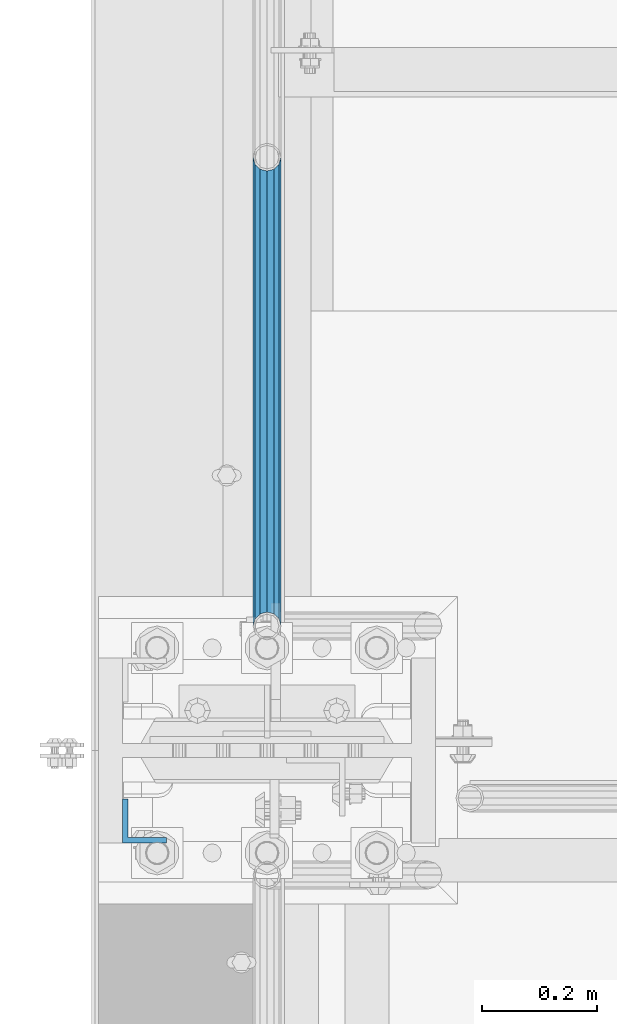
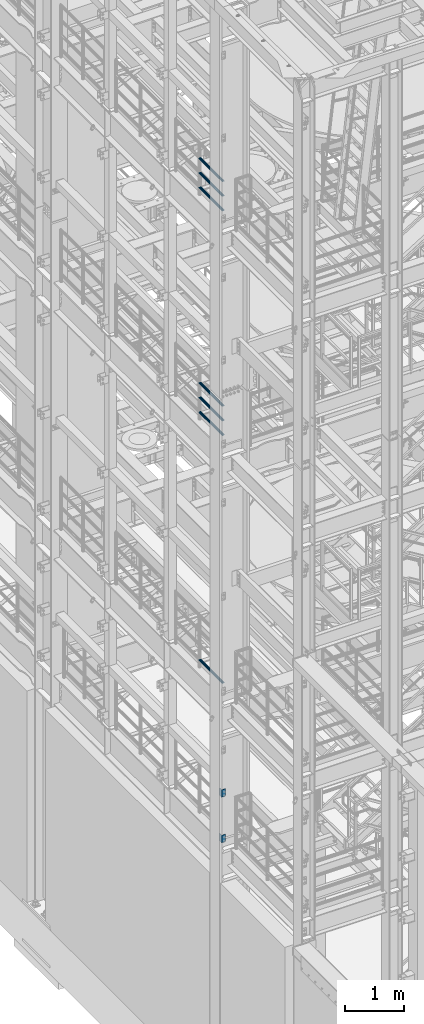
# One storey, part 1161 of 1876: 9 beams, 4 elements without a shape of their own.
"""IFC2X3 building model written with IfcOpenShell, lengths in millimetres."""

import ifcopenshell
import ifcopenshell.guid

model = None  # the IFC model being written
_history = None  # IfcOwnerHistory: only IFC2X3 demands one
_inside = {}  # id of a spatial element -> (the spatial element, [elements in it])
_under = {}  # id of a project, library or spatial element -> (it, [spatial elements below it])
_declared = {}  # id of a project -> (the project, [libraries it declares])
_typed = {}  # id of a type object -> (the type object, [elements of that type])
_made_of = {}  # id of a material, layer set ... -> (it, [elements and type objects made of it])


def new_model(schema):
    """Start an empty IFC model of exactly this schema.

    Asked for "IFC4X3", IfcOpenShell would pick the latest addendum, in which some entities
    have other attributes; the version numbers below select the first issue.
    IFC2X3 requires an IfcOwnerHistory on every rooted entity: one is made here for all.
    """
    global model, _history
    if schema == "IFC4X3":
        model = ifcopenshell.file(schema_version=(4, 3, 0, 0))
    else:
        model = ifcopenshell.file(schema=schema)
    _inside.clear()
    _under.clear()
    _declared.clear()
    _typed.clear()
    _made_of.clear()
    _history = None
    if model.schema == "IFC2X3":
        org = make("IfcOrganization", Name="unknown")
        user = make(
            "IfcPersonAndOrganization",
            ThePerson=make("IfcPerson", FamilyName="unknown"),
            TheOrganization=org,
        )
        app = make(
            "IfcApplication",
            ApplicationDeveloper=org,
            Version="unknown",
            ApplicationFullName="unknown",
            ApplicationIdentifier="unknown",
        )
        _history = make(
            "IfcOwnerHistory",
            OwningUser=user,
            OwningApplication=app,
            ChangeAction="ADDED",
            CreationDate=0,
        )
    return model


def make(cls, **values):
    """One entity of the class cls with the attributes given. An attribute that is None is left unset."""
    return model.create_entity(
        cls, **{name: value for name, value in values.items() if value is not None}
    )


def rooted(cls, **values):
    """An entity with a GlobalId (a new one), such as an element, a storey or a relation."""
    return make(cls, GlobalId=ifcopenshell.guid.new(), OwnerHistory=_history, **values)


def si_unit(unit_type, name, prefix=None):
    """IfcSIUnit, for example si_unit("LENGTHUNIT", "METRE", prefix="MILLI")."""
    return make("IfcSIUnit", UnitType=unit_type, Prefix=prefix, Name=name)


def assignment(units):
    """IfcUnitAssignment: the units of a project."""
    return None if units is None else make("IfcUnitAssignment", Units=units)


def point(xyz):
    """IfcCartesianPoint."""
    return None if xyz is None else make("IfcCartesianPoint", Coordinates=xyz)


def direction(xyz):
    """IfcDirection."""
    return None if xyz is None else make("IfcDirection", DirectionRatios=xyz)


def frame(location, z_axis=None, x_axis=None):
    """IfcAxis2Placement3D, a coordinate frame: its origin and axes. An axis left out is left unset."""
    return make(
        "IfcAxis2Placement3D",
        Location=point(location),
        Axis=direction(z_axis),
        RefDirection=direction(x_axis),
    )


def origin_with_axes():
    """The frame at (0, 0, 0) with the z axis (0, 0, 1) and the x axis (1, 0, 0) written out."""
    return frame((0.0, 0.0, 0.0), z_axis=(0.0, 0.0, 1.0), x_axis=(1.0, 0.0, 0.0))


def place(relative_to, where):
    """IfcLocalPlacement: puts the frame where relative to a parent placement (None: the world)."""
    return make(
        "IfcLocalPlacement", PlacementRelTo=relative_to, RelativePlacement=where
    )


def context(
    kind, dimensions, precision=None, world=None, true_north=None, identifier=None
):
    """IfcGeometricRepresentationContext, for example the 3D "Model" context."""
    return make(
        "IfcGeometricRepresentationContext",
        ContextIdentifier=identifier,
        ContextType=kind,
        CoordinateSpaceDimension=dimensions,
        Precision=precision,
        WorldCoordinateSystem=world,
        TrueNorth=true_north,
    )


def subcontext(parent, identifier, kind, view, scale=None):
    """IfcGeometricRepresentationSubContext, for example "Body" below "Model"."""
    return make(
        "IfcGeometricRepresentationSubContext",
        ContextIdentifier=identifier,
        ContextType=kind,
        ParentContext=parent,
        TargetScale=scale,
        TargetView=view,
    )


def project(units=None, contexts=None):
    """IfcProject with its units and contexts."""
    return rooted(
        "IfcProject",
        Name="project",
        RepresentationContexts=contexts,
        UnitsInContext=assignment(units),
    )


def spatial(cls, under=None, at=None, **own):
    """A site, building, storey or space (cls), placed at a placement, below another one or the project."""
    s = rooted(cls, ObjectPlacement=at, **own)
    if under is not None:
        _under.setdefault(under.id(), (under, []))[1].append(s)
    return s


def faces_of(points, faces, orient=None, outer=None):
    """IfcFace entities. A face is a list of loops; a loop is a list of indices into points, from 0.

    orient and outer hold one flag for each loop. By default every Orientation is true, the
    first loop of a face is its IfcFaceOuterBound and the others are IfcFaceBound.
    """
    made = []
    for i, loops in enumerate(faces):
        bounds = []
        for j, loop in enumerate(loops):
            is_outer = j == 0 if outer is None else outer[i][j]
            bounds.append(
                make(
                    "IfcFaceOuterBound" if is_outer else "IfcFaceBound",
                    Bound=make("IfcPolyLoop", Polygon=[points[k] for k in loop]),
                    Orientation=True if orient is None else orient[i][j],
                )
            )
        made.append(make("IfcFace", Bounds=bounds))
    return made


def faceted_brep(points, faces, orient=None, outer=None, voids=None):
    """IfcFacetedBrep: a solid bounded by flat faces; with voids (closed shells), ...WithVoids."""
    shared = [point(p) for p in points]
    hull = make("IfcClosedShell", CfsFaces=faces_of(shared, faces, orient, outer))
    if voids is None:
        return make("IfcFacetedBrep", Outer=hull)
    return make(
        "IfcFacetedBrepWithVoids",
        Outer=hull,
        Voids=[
            make(cls, CfsFaces=faces_of(shared, fs, o, b)) for cls, fs, o, b in voids
        ],
    )


def shape(context_of_items, identifier, shape_type, items):
    """IfcShapeRepresentation: the items that make up one representation, for example the "Body"."""
    return make(
        "IfcShapeRepresentation",
        ContextOfItems=context_of_items,
        RepresentationIdentifier=identifier,
        RepresentationType=shape_type,
        Items=items,
    )


def material(Name=None, Category=None):
    """IfcMaterial."""
    return make("IfcMaterial", Name=Name, Category=Category)


def made_of(thing, what):
    """Note that an element or type object is made of a material, layer set ...; save() writes the relation."""
    if what is not None:
        _made_of.setdefault(what.id(), (what, []))[1].append(thing)
    return thing


def type_object(cls, material=None, **own):
    """A type object (cls), such as IfcWallType, which elements share."""
    return made_of(rooted(cls, **own), material)


def element(
    cls,
    number,
    at=None,
    inside=None,
    cuts=None,
    type_object=None,
    material=None,
    context=None,
    identifier="Body",
    shape_type=None,
    held_by="IfcProductDefinitionShape",
    body=None,
    shapes=None,
    **own,
):
    """One element of the class cls, such as IfcWall. Its Tag is "e" and its number.

    at: its placement. inside: the storey or other place that contains it. cuts: it is an
    opening in that element (IfcRelVoidsElement). A single representation is given by context,
    identifier, shape_type and body (its items); several are given by shapes. held_by: the class
    of the entity that holds the representations. save() writes the other relations.
    """
    e = rooted(cls, Tag="e%d" % number, ObjectPlacement=at, **own)
    if body is not None:
        shapes = [shape(context, identifier, shape_type, body)]
    if shapes is not None:
        e.Representation = make(held_by, Representations=shapes)
    if inside is not None:
        _inside.setdefault(inside.id(), (inside, []))[1].append(e)
    if cuts is not None:
        rooted(
            "IfcRelVoidsElement", RelatingBuildingElement=cuts, RelatedOpeningElement=e
        )
    if type_object is not None:
        _typed.setdefault(type_object.id(), (type_object, []))[1].append(e)
    return made_of(e, material)


def aggregate(whole, parts):
    """IfcRelAggregates: a whole, such as a stair, and the parts it consists of."""
    return rooted("IfcRelAggregates", RelatingObject=whole, RelatedObjects=parts)


def save(model, path):
    """Write the relations noted so far, then the file.

    IfcRelAggregates (storeys below a building ...), IfcRelContainedInSpatialStructure (elements
    in a storey), IfcRelDefinesByType, IfcRelAssociatesMaterial and IfcRelDeclares: one each for
    every whole, place, type object, material and project.
    """
    for whole, parts in _under.values():
        aggregate(whole, parts)
    for where, things in _inside.values():
        rooted(
            "IfcRelContainedInSpatialStructure",
            RelatedElements=things,
            RelatingStructure=where,
        )
    for kind, things in _typed.values():
        rooted("IfcRelDefinesByType", RelatedObjects=things, RelatingType=kind)
    for what, things in _made_of.values():
        rooted("IfcRelAssociatesMaterial", RelatedObjects=things, RelatingMaterial=what)
    for by, libraries in _declared.values():
        rooted("IfcRelDeclares", RelatingContext=by, RelatedDefinitions=libraries)
    model.write(path)


model = new_model("IFC2X3")

# Units and contexts
model_context = context("Model", 3, precision=1e-05, world=origin_with_axes())
body_context = subcontext(model_context, "Body", "Model", "MODEL_VIEW")
ifc_project = project(units=[si_unit("LENGTHUNIT", "METRE", prefix="MILLI"), si_unit("AREAUNIT", "SQUARE_METRE"), si_unit("VOLUMEUNIT", "CUBIC_METRE"), si_unit("MASSUNIT", "GRAM", prefix="KILO"), si_unit("TIMEUNIT", "SECOND"), si_unit("PLANEANGLEUNIT", "RADIAN"), si_unit("SOLIDANGLEUNIT", "STERADIAN"), si_unit("THERMODYNAMICTEMPERATUREUNIT", "DEGREE_CELSIUS"), si_unit("LUMINOUSINTENSITYUNIT", "LUMEN")], contexts=[model_context])

# Site, building, storey
site_placement = place(None, origin_with_axes())
site = spatial("IfcSite", under=ifc_project, at=site_placement, CompositionType="ELEMENT")
building_placement = place(site_placement, origin_with_axes())
building = spatial("IfcBuilding", under=site, at=building_placement, Name="Undefined", CompositionType="ELEMENT")
storey_placement = place(building_placement, origin_with_axes())
storey = spatial("IfcBuildingStorey", under=building, at=storey_placement, Name="Undefined", CompositionType="ELEMENT", Elevation=0.0)

# Assembly, beams
assembly_1_placement = place(storey_placement, origin_with_axes())
assembly_1 = element("IfcElementAssembly", 1, at=assembly_1_placement, inside=storey, Name="RAIL", AssemblyPlace="NOTDEFINED", PredefinedType="RIGID_FRAME")
ifc_material_1 = material()
beam_type_1 = type_object("IfcBeamType", Name="PIPE1-1/2SCH40", PredefinedType="NOTDEFINED")
beam_1_placement = place(assembly_1_placement, frame((6.13908923696727e-12, -3542.7031, 18145.125), z_axis=(0.0, 0.0, 1.0), x_axis=(0.0, -1.0, 0.0)))
beam_1 = element("IfcBeam", 2, at=beam_1_placement, type_object=beam_type_1, material=ifc_material_1, Name="RAIL", ObjectType="PIPE1-1/2SCH40", context=body_context, shape_type="Brep", body=[
    faceted_brep([(792.499707006684, -12.0649999999996, 20.8971929933177), (792.499707006684, -12.0650000000314, 15.8661214311469), (792.006278568813, -10.2235000000001, 17.7076214311819), (789.266900000001, -9.09494701772928e-13, 20.4470000000001), (789.266900000001, -9.09494701772928e-13, 24.130000000001), (792.00627856883, 10.2235000000001, 17.7076214311819), (792.499707006684, 12.0649999999678, 15.8661214312124), (792.499707006684, 12.0649999999996, 20.8971929933177), (813.396900000002, 24.1300000000001, 0.0), (801.331900000001, 20.8971929933186, 12.0649999999987), (801.331900000001, 20.8971929933186, -12.0649999999987), (798.142328437896, 17.7076214311801, 10.2235000000001), (800.881707006714, 20.4470000000001, 0.0), (798.142328437896, 17.7076214311801, -10.2235000000001), (792.499707006684, 12.0649999999678, -15.8661214312124), (792.499707006684, 12.0649999999996, -20.8971929933177), (792.00627856883, 10.2235000000001, -17.7076214311819), (789.266900000001, 0.0, -20.4470000000001), (789.266900000001, 0.0, -24.130000000001), (792.499707006684, -12.0650000000314, -15.8661214311469), (792.499707006684, -12.0649999999996, -20.8971929933177), (792.006278568813, -10.2235000000001, -17.7076214311819), (813.396900000002, -24.1300000000319, 0.0), (801.331900000001, -20.8971929933186, -12.0649999999987), (801.331900000001, -20.8971929933186, 12.0649999999987), (798.142328437831, -17.7076214311801, -10.2235000000001), (800.881707006651, -20.4470000000001, 0.0), (798.142328437831, -17.7076214311801, 10.2235000000001), (12.0650000000064, -20.8971929933177, -12.0649999999987), (20.8971929933249, -12.0650000000005, -20.8971929933177), (0.0, 24.1299999999992, 0.0), (12.0650000000064, 20.8971929933177, -12.0649999999987), (12.0650000000064, 20.8971929933177, 12.0649999999987), (20.8971929933249, 12.0650000000005, 20.8971929933177), (24.1300000000064, 0.0, 24.130000000001), (20.8971929933249, 12.0650000000005, -20.8971929933177), (24.1300000000063, 0.0, -24.130000000001), (24.1300000000063, 0.0, -20.4470000000001), (20.8971929933249, -12.0650000000005, -15.8661214311796), (21.3906214311868, -10.2235000000001, -17.7076214311819), (21.3906214311868, 10.2235000000001, -17.7076214311819), (20.8971929933249, 12.0650000000005, -15.8661214311796), (15.2545715621445, 17.7076214311801, -10.2235000000001), (12.5151929933249, 20.4470000000001, 0.0), (15.2545715621445, 17.7076214311801, 10.2235000000001), (20.8971929933249, 12.0650000000005, 15.8661214311796), (21.3906214311868, 10.2235000000001, 17.7076214311819), (24.1300000000064, 0.0, 20.4470000000001), (21.3906214311868, -10.2235000000001, 17.7076214311819), (20.8971929933249, -12.0650000000005, 15.8661214311796), (20.8971929933249, -12.0650000000005, 20.8971929933177), (12.0650000000064, -20.8971929933177, 12.0649999999987), (0.0, -24.1299999999992, 0.0), (15.2545715621445, -17.7076214311801, 10.2235000000001), (12.5151929933249, -20.4470000000001, 0.0), (15.2545715621445, -17.7076214311801, -10.2235000000001)], [[[0, 1, 2, 3, 4]], [[4, 3, 5, 6, 7]], [[8, 9, 10]], [[7, 6, 11, 12, 13, 14, 15, 10, 9]], [[16, 17, 18, 15, 14]], [[19, 20, 18, 17, 21]], [[22, 23, 24]], [[24, 23, 20, 19, 25, 26, 27, 1, 0]], [[28, 29, 20, 23]], [[30, 31, 32]], [[33, 34, 4, 7]], [[32, 33, 7, 9]], [[30, 32, 9, 8]], [[31, 30, 8, 10]], [[35, 31, 10, 15]], [[36, 35, 15, 18]], [[29, 36, 18, 20]], [[37, 36, 29, 38, 39]], [[40, 41, 35, 36, 37]], [[32, 31, 35, 41, 42, 43, 44, 45, 33]], [[33, 45, 46, 47, 34]], [[34, 47, 48, 49, 50]], [[34, 50, 0, 4]], [[50, 51, 24, 0]], [[51, 52, 22, 24]], [[52, 28, 23, 22]], [[51, 28, 52]], [[50, 49, 53, 54, 55, 38, 29, 28, 51]], [[55, 54, 26, 25]], [[21, 39, 38, 55, 25, 19]], [[37, 39, 21, 17]], [[40, 37, 17, 16]], [[42, 41, 40, 16, 14, 13]], [[43, 42, 13, 12]], [[44, 43, 12, 11]], [[5, 46, 45, 44, 11, 6]], [[47, 46, 5, 3]], [[48, 47, 3, 2]], [[53, 49, 48, 2, 1, 27]], [[54, 53, 27, 26]]]),
])
beam_2_placement = place(assembly_1_placement, frame((-1.00044417195022e-11, -4356.1, 18449.925000036), z_axis=(0.0, 0.0, -1.0), x_axis=(0.0, 1.0, 0.0)))
beam_2 = element("IfcBeam", 3, at=beam_2_placement, type_object=beam_type_1, material=ifc_material_1, Name="RAIL", ObjectType="PIPE1-1/2SCH40", context=body_context, shape_type="Brep", body=[
    faceted_brep([(0.0, 24.1299999999992, 0.0), (12.0650000000064, 20.8971929933177, -12.0649999999987), (12.0650000000064, 20.8971929933177, 12.0649999999987), (12.0650000000064, -20.8971929933177, 12.0649999999987), (12.0650000000064, -20.8971929933177, -12.0649999999987), (0.0, -24.1299999999992, 0.0), (20.8971929933249, -12.0650000000005, 20.8971929933177), (20.8971929933249, -12.0650000000005, 15.8661214311796), (15.2545715621445, -17.7076214311801, 10.2235000000001), (12.5151929933249, -20.4470000000001, 0.0), (15.2545715621445, -17.7076214311801, -10.2235000000001), (20.8971929933249, -12.0650000000005, -15.8661214311796), (20.8971929933249, -12.0650000000005, -20.8971929933177), (24.1300000000063, 0.0, -20.4470000000001), (24.1300000000063, 0.0, -24.130000000001), (21.3906214311868, -10.2235000000001, -17.7076214311819), (21.3906214311868, 10.2235000000001, -17.7076214311819), (20.8971929933249, 12.0650000000005, -15.8661214311796), (20.8971929933249, 12.0650000000005, -20.8971929933177), (15.2545715621445, 17.7076214311801, -10.2235000000001), (12.5151929933249, 20.4470000000001, 0.0), (15.2545715621445, 17.7076214311801, 10.2235000000001), (20.8971929933249, 12.0650000000005, 15.8661214311796), (20.8971929933249, 12.0650000000005, 20.8971929933177), (21.3906214311868, 10.2235000000001, 17.7076214311819), (24.1300000000064, 0.0, 20.4470000000001), (24.1300000000064, 0.0, 24.130000000001), (21.3906214311868, -10.2235000000001, 17.7076214311819), (813.396900000002, 24.1300000000001, 0.0), (801.331900000001, 20.8971929933186, -12.0649999999987), (792.499707006684, 12.0649999999996, -20.8971929933177), (813.396900000002, -24.1300000000319, 0.0), (801.331900000001, -20.8971929933186, -12.0649999999987), (801.331900000001, -20.8971929933186, 12.0649999999987), (792.499707006684, -12.0649999999996, 20.8971929933177), (792.499707006684, -12.0649999999996, -20.8971929933177), (789.266900000001, 0.0, -24.130000000001), (792.00627856883, 10.2235000000001, -17.7076214311819), (789.266900000001, 0.0, -20.4470000000001), (792.499707006684, 12.0649999999678, -15.8661214312124), (792.499707006684, -12.0650000000314, -15.8661214311469), (792.006278568813, -10.2235000000001, -17.7076214311819), (798.142328437831, -17.7076214311801, -10.2235000000001), (800.881707006651, -20.4470000000001, 0.0), (798.142328437831, -17.7076214311801, 10.2235000000001), (792.499707006684, -12.0650000000314, 15.8661214311469), (792.006278568813, -10.2235000000001, 17.7076214311819), (789.266900000001, -9.09494701772928e-13, 20.4470000000001), (789.266900000001, -9.09494701772928e-13, 24.130000000001), (792.499707006684, 12.0649999999996, 20.8971929933177), (801.331900000001, 20.8971929933186, 12.0649999999987), (792.499707006684, 12.0649999999678, 15.8661214312124), (798.142328437896, 17.7076214311801, 10.2235000000001), (800.881707006714, 20.4470000000001, 0.0), (798.142328437896, 17.7076214311801, -10.2235000000001), (792.00627856883, 10.2235000000001, 17.7076214311819)], [[[0, 1, 2]], [[3, 4, 5]], [[6, 7, 8, 9, 10, 11, 12, 4, 3]], [[13, 14, 12, 11, 15]], [[16, 17, 18, 14, 13]], [[2, 1, 18, 17, 19, 20, 21, 22, 23]], [[23, 22, 24, 25, 26]], [[26, 25, 27, 7, 6]], [[1, 0, 28, 29]], [[18, 1, 29, 30]], [[31, 32, 33]], [[6, 3, 33, 34]], [[3, 5, 31, 33]], [[5, 4, 32, 31]], [[4, 12, 35, 32]], [[12, 14, 36, 35]], [[14, 18, 30, 36]], [[37, 38, 36, 30, 39]], [[40, 35, 36, 38, 41]], [[33, 32, 35, 40, 42, 43, 44, 45, 34]], [[34, 45, 46, 47, 48]], [[26, 6, 34, 48]], [[2, 23, 49, 50]], [[23, 26, 48, 49]], [[0, 2, 50, 28]], [[28, 50, 29]], [[49, 51, 52, 53, 54, 39, 30, 29, 50]], [[48, 47, 55, 51, 49]], [[25, 24, 55, 47]], [[55, 24, 22, 21, 52, 51]], [[21, 20, 53, 52]], [[20, 19, 54, 53]], [[19, 17, 16, 37, 39, 54]], [[16, 13, 38, 37]], [[13, 15, 41, 38]], [[41, 15, 11, 10, 42, 40]], [[10, 9, 43, 42]], [[9, 8, 44, 43]], [[8, 7, 27, 46, 45, 44]], [[27, 25, 47, 46]]]),
])
beam_3_placement = place(assembly_1_placement, frame((-1.00044417195022e-11, -4356.1, 18754.7250000359), z_axis=(0.0, 0.0, -1.0), x_axis=(0.0, 1.0, 0.0)))
beam_3 = element("IfcBeam", 4, at=beam_3_placement, type_object=beam_type_1, material=ifc_material_1, Name="RAIL", ObjectType="PIPE1-1/2SCH40", context=body_context, shape_type="Brep", body=[
    faceted_brep([(0.0, 24.1299999999992, 0.0), (12.0650000000064, 20.8971929933177, -12.0649999999987), (12.0650000000064, 20.8971929933177, 12.0649999999987), (12.0650000000064, -20.8971929933177, 12.0649999999987), (12.0650000000064, -20.8971929933177, -12.0649999999987), (0.0, -24.1299999999992, 0.0), (20.8971929933249, -12.0650000000005, 20.8971929933177), (20.8971929933249, -12.0650000000005, 15.8661214311796), (15.2545715621445, -17.7076214311801, 10.2235000000001), (12.5151929933249, -20.4470000000001, 0.0), (15.2545715621445, -17.7076214311801, -10.2235000000001), (20.8971929933249, -12.0650000000005, -15.8661214311796), (20.8971929933249, -12.0650000000005, -20.8971929933177), (24.1300000000063, 0.0, -20.4470000000001), (24.1300000000063, 0.0, -24.130000000001), (21.3906214311868, -10.2235000000001, -17.7076214311819), (21.3906214311868, 10.2235000000001, -17.7076214311819), (20.8971929933249, 12.0650000000005, -15.8661214311796), (20.8971929933249, 12.0650000000005, -20.8971929933177), (15.2545715621445, 17.7076214311801, -10.2235000000001), (12.5151929933249, 20.4470000000001, 0.0), (15.2545715621445, 17.7076214311801, 10.2235000000001), (20.8971929933249, 12.0650000000005, 15.8661214311796), (20.8971929933249, 12.0650000000005, 20.8971929933177), (21.3906214311868, 10.2235000000001, 17.7076214311819), (24.1300000000064, 0.0, 20.4470000000001), (24.1300000000064, 0.0, 24.130000000001), (21.3906214311868, -10.2235000000001, 17.7076214311819), (813.396900000002, 24.1300000000001, 0.0), (801.331900000001, 20.8971929933186, -12.0649999999987), (792.499707006684, 12.0649999999996, -20.8971929933177), (813.396900000002, -24.1300000000319, 0.0), (801.331900000001, -20.8971929933186, -12.0649999999987), (801.331900000001, -20.8971929933186, 12.0649999999987), (792.499707006684, -12.0649999999996, 20.8971929933177), (792.499707006684, -12.0649999999996, -20.8971929933177), (789.266900000001, 0.0, -24.130000000001), (792.00627856883, 10.2235000000001, -17.7076214311819), (789.266900000001, 0.0, -20.4470000000001), (792.499707006684, 12.0649999999678, -15.8661214312124), (792.499707006684, -12.0650000000314, -15.8661214311469), (792.006278568813, -10.2235000000001, -17.7076214311819), (798.142328437831, -17.7076214311801, -10.2235000000001), (800.881707006651, -20.4470000000001, 0.0), (798.142328437831, -17.7076214311801, 10.2235000000001), (792.499707006684, -12.0650000000314, 15.8661214311469), (792.006278568813, -10.2235000000001, 17.7076214311819), (789.266900000001, -9.09494701772928e-13, 20.4470000000001), (789.266900000001, -9.09494701772928e-13, 24.130000000001), (792.499707006684, 12.0649999999996, 20.8971929933177), (801.331900000001, 20.8971929933186, 12.0649999999987), (792.499707006684, 12.0649999999678, 15.8661214312124), (798.142328437896, 17.7076214311801, 10.2235000000001), (800.881707006714, 20.4470000000001, 0.0), (798.142328437896, 17.7076214311801, -10.2235000000001), (792.00627856883, 10.2235000000001, 17.7076214311819)], [[[0, 1, 2]], [[3, 4, 5]], [[6, 7, 8, 9, 10, 11, 12, 4, 3]], [[13, 14, 12, 11, 15]], [[16, 17, 18, 14, 13]], [[2, 1, 18, 17, 19, 20, 21, 22, 23]], [[23, 22, 24, 25, 26]], [[26, 25, 27, 7, 6]], [[1, 0, 28, 29]], [[18, 1, 29, 30]], [[31, 32, 33]], [[6, 3, 33, 34]], [[3, 5, 31, 33]], [[5, 4, 32, 31]], [[4, 12, 35, 32]], [[12, 14, 36, 35]], [[14, 18, 30, 36]], [[37, 38, 36, 30, 39]], [[40, 35, 36, 38, 41]], [[33, 32, 35, 40, 42, 43, 44, 45, 34]], [[34, 45, 46, 47, 48]], [[26, 6, 34, 48]], [[2, 23, 49, 50]], [[23, 26, 48, 49]], [[0, 2, 50, 28]], [[28, 50, 29]], [[49, 51, 52, 53, 54, 39, 30, 29, 50]], [[48, 47, 55, 51, 49]], [[25, 24, 55, 47]], [[55, 24, 22, 21, 52, 51]], [[21, 20, 53, 52]], [[20, 19, 54, 53]], [[19, 17, 16, 37, 39, 54]], [[16, 13, 38, 37]], [[13, 15, 41, 38]], [[41, 15, 11, 10, 42, 40]], [[10, 9, 43, 42]], [[9, 8, 44, 43]], [[8, 7, 27, 46, 45, 44]], [[27, 25, 47, 46]]]),
])
aggregate(assembly_1, [beam_1, beam_2, beam_3])

assembly_2_placement = place(storey_placement, origin_with_axes())
assembly_2 = element("IfcElementAssembly", 5, at=assembly_2_placement, inside=storey, Name="RAIL", AssemblyPlace="NOTDEFINED", PredefinedType="RIGID_FRAME")
beam_4_placement = place(assembly_2_placement, frame((6.13908923696727e-12, -3542.7031, 13471.525), z_axis=(0.0, 0.0, 1.0), x_axis=(0.0, -1.0, 0.0)))
beam_4 = element("IfcBeam", 6, at=beam_4_placement, type_object=beam_type_1, material=ifc_material_1, Name="RAIL", ObjectType="PIPE1-1/2SCH40", context=body_context, shape_type="Brep", body=[
    faceted_brep([(792.499707006684, -12.0649999999996, 20.8971929933177), (792.499707006684, -12.0650000000314, 15.8661214311469), (792.006278568813, -10.2235000000001, 17.7076214311819), (789.266900000001, -9.09494701772928e-13, 20.4470000000001), (789.266900000001, -9.09494701772928e-13, 24.130000000001), (792.00627856883, 10.2235000000001, 17.7076214311819), (792.499707006684, 12.0649999999678, 15.8661214312124), (792.499707006684, 12.0649999999996, 20.8971929933177), (813.396900000002, 24.1300000000001, 0.0), (801.331900000001, 20.8971929933186, 12.0649999999987), (801.331900000001, 20.8971929933186, -12.0649999999987), (798.142328437896, 17.7076214311801, 10.2235000000001), (800.881707006714, 20.4470000000001, 0.0), (798.142328437896, 17.7076214311801, -10.2235000000001), (792.499707006684, 12.0649999999678, -15.8661214312124), (792.499707006684, 12.0649999999996, -20.8971929933177), (792.00627856883, 10.2235000000001, -17.7076214311819), (789.266900000001, 0.0, -20.4470000000001), (789.266900000001, 0.0, -24.130000000001), (792.499707006684, -12.0650000000314, -15.8661214311469), (792.499707006684, -12.0649999999996, -20.8971929933177), (792.006278568813, -10.2235000000001, -17.7076214311819), (813.396900000002, -24.1300000000319, 0.0), (801.331900000001, -20.8971929933186, -12.0649999999987), (801.331900000001, -20.8971929933186, 12.0649999999987), (798.142328437831, -17.7076214311801, -10.2235000000001), (800.881707006651, -20.4470000000001, 0.0), (798.142328437831, -17.7076214311801, 10.2235000000001), (12.0650000000064, -20.8971929933177, -12.0649999999987), (20.8971929933249, -12.0650000000005, -20.8971929933177), (0.0, 24.1299999999992, 0.0), (12.0650000000064, 20.8971929933177, -12.0649999999987), (12.0650000000064, 20.8971929933177, 12.0649999999987), (20.8971929933249, 12.0650000000005, 20.8971929933177), (24.1300000000064, 0.0, 24.130000000001), (20.8971929933249, 12.0650000000005, -20.8971929933177), (24.1300000000063, 0.0, -24.130000000001), (24.1300000000063, 0.0, -20.4470000000001), (20.8971929933249, -12.0650000000005, -15.8661214311796), (21.3906214311868, -10.2235000000001, -17.7076214311819), (21.3906214311868, 10.2235000000001, -17.7076214311819), (20.8971929933249, 12.0650000000005, -15.8661214311796), (15.2545715621445, 17.7076214311801, -10.2235000000001), (12.5151929933249, 20.4470000000001, 0.0), (15.2545715621445, 17.7076214311801, 10.2235000000001), (20.8971929933249, 12.0650000000005, 15.8661214311796), (21.3906214311868, 10.2235000000001, 17.7076214311819), (24.1300000000064, 0.0, 20.4470000000001), (21.3906214311868, -10.2235000000001, 17.7076214311819), (20.8971929933249, -12.0650000000005, 15.8661214311796), (20.8971929933249, -12.0650000000005, 20.8971929933177), (12.0650000000064, -20.8971929933177, 12.0649999999987), (0.0, -24.1299999999992, 0.0), (15.2545715621445, -17.7076214311801, 10.2235000000001), (12.5151929933249, -20.4470000000001, 0.0), (15.2545715621445, -17.7076214311801, -10.2235000000001)], [[[0, 1, 2, 3, 4]], [[4, 3, 5, 6, 7]], [[8, 9, 10]], [[7, 6, 11, 12, 13, 14, 15, 10, 9]], [[16, 17, 18, 15, 14]], [[19, 20, 18, 17, 21]], [[22, 23, 24]], [[24, 23, 20, 19, 25, 26, 27, 1, 0]], [[28, 29, 20, 23]], [[30, 31, 32]], [[33, 34, 4, 7]], [[32, 33, 7, 9]], [[30, 32, 9, 8]], [[31, 30, 8, 10]], [[35, 31, 10, 15]], [[36, 35, 15, 18]], [[29, 36, 18, 20]], [[37, 36, 29, 38, 39]], [[40, 41, 35, 36, 37]], [[32, 31, 35, 41, 42, 43, 44, 45, 33]], [[33, 45, 46, 47, 34]], [[34, 47, 48, 49, 50]], [[34, 50, 0, 4]], [[50, 51, 24, 0]], [[51, 52, 22, 24]], [[52, 28, 23, 22]], [[51, 28, 52]], [[50, 49, 53, 54, 55, 38, 29, 28, 51]], [[55, 54, 26, 25]], [[21, 39, 38, 55, 25, 19]], [[37, 39, 21, 17]], [[40, 37, 17, 16]], [[42, 41, 40, 16, 14, 13]], [[43, 42, 13, 12]], [[44, 43, 12, 11]], [[5, 46, 45, 44, 11, 6]], [[47, 46, 5, 3]], [[48, 47, 3, 2]], [[53, 49, 48, 2, 1, 27]], [[54, 53, 27, 26]]]),
])
beam_5_placement = place(assembly_2_placement, frame((-1.00044417195022e-11, -4356.1, 13776.325000036), z_axis=(0.0, 0.0, -1.0), x_axis=(0.0, 1.0, 0.0)))
beam_5 = element("IfcBeam", 7, at=beam_5_placement, type_object=beam_type_1, material=ifc_material_1, Name="RAIL", ObjectType="PIPE1-1/2SCH40", context=body_context, shape_type="Brep", body=[
    faceted_brep([(0.0, 24.1299999999992, 0.0), (12.0650000000064, 20.8971929933177, -12.0649999999987), (12.0650000000064, 20.8971929933177, 12.0649999999987), (12.0650000000064, -20.8971929933177, 12.0649999999987), (12.0650000000064, -20.8971929933177, -12.0649999999987), (0.0, -24.1299999999992, 0.0), (20.8971929933249, -12.0650000000005, 20.8971929933177), (20.8971929933249, -12.0650000000005, 15.8661214311796), (15.2545715621445, -17.7076214311801, 10.2235000000001), (12.5151929933249, -20.4470000000001, 0.0), (15.2545715621445, -17.7076214311801, -10.2235000000001), (20.8971929933249, -12.0650000000005, -15.8661214311796), (20.8971929933249, -12.0650000000005, -20.8971929933177), (24.1300000000063, 0.0, -20.4470000000001), (24.1300000000063, 0.0, -24.130000000001), (21.3906214311868, -10.2235000000001, -17.7076214311819), (21.3906214311868, 10.2235000000001, -17.7076214311819), (20.8971929933249, 12.0650000000005, -15.8661214311796), (20.8971929933249, 12.0650000000005, -20.8971929933177), (15.2545715621445, 17.7076214311801, -10.2235000000001), (12.5151929933249, 20.4470000000001, 0.0), (15.2545715621445, 17.7076214311801, 10.2235000000001), (20.8971929933249, 12.0650000000005, 15.8661214311796), (20.8971929933249, 12.0650000000005, 20.8971929933177), (21.3906214311868, 10.2235000000001, 17.7076214311819), (24.1300000000064, 0.0, 20.4470000000001), (24.1300000000064, 0.0, 24.130000000001), (21.3906214311868, -10.2235000000001, 17.7076214311819), (813.396900000002, 24.1300000000001, 0.0), (801.331900000001, 20.8971929933186, -12.0649999999987), (792.499707006684, 12.0649999999996, -20.8971929933177), (813.396900000002, -24.1300000000319, 0.0), (801.331900000001, -20.8971929933186, -12.0649999999987), (801.331900000001, -20.8971929933186, 12.0649999999987), (792.499707006684, -12.0649999999996, 20.8971929933177), (792.499707006684, -12.0649999999996, -20.8971929933177), (789.266900000001, 0.0, -24.130000000001), (792.00627856883, 10.2235000000001, -17.7076214311819), (789.266900000001, 0.0, -20.4470000000001), (792.499707006684, 12.0649999999678, -15.8661214312124), (792.499707006684, -12.0650000000314, -15.8661214311469), (792.006278568813, -10.2235000000001, -17.7076214311819), (798.142328437831, -17.7076214311801, -10.2235000000001), (800.881707006651, -20.4470000000001, 0.0), (798.142328437831, -17.7076214311801, 10.2235000000001), (792.499707006684, -12.0650000000314, 15.8661214311469), (792.006278568813, -10.2235000000001, 17.7076214311819), (789.266900000001, -9.09494701772928e-13, 20.4470000000001), (789.266900000001, -9.09494701772928e-13, 24.130000000001), (792.499707006684, 12.0649999999996, 20.8971929933177), (801.331900000001, 20.8971929933186, 12.0649999999987), (792.499707006684, 12.0649999999678, 15.8661214312124), (798.142328437896, 17.7076214311801, 10.2235000000001), (800.881707006714, 20.4470000000001, 0.0), (798.142328437896, 17.7076214311801, -10.2235000000001), (792.00627856883, 10.2235000000001, 17.7076214311819)], [[[0, 1, 2]], [[3, 4, 5]], [[6, 7, 8, 9, 10, 11, 12, 4, 3]], [[13, 14, 12, 11, 15]], [[16, 17, 18, 14, 13]], [[2, 1, 18, 17, 19, 20, 21, 22, 23]], [[23, 22, 24, 25, 26]], [[26, 25, 27, 7, 6]], [[1, 0, 28, 29]], [[18, 1, 29, 30]], [[31, 32, 33]], [[6, 3, 33, 34]], [[3, 5, 31, 33]], [[5, 4, 32, 31]], [[4, 12, 35, 32]], [[12, 14, 36, 35]], [[14, 18, 30, 36]], [[37, 38, 36, 30, 39]], [[40, 35, 36, 38, 41]], [[33, 32, 35, 40, 42, 43, 44, 45, 34]], [[34, 45, 46, 47, 48]], [[26, 6, 34, 48]], [[2, 23, 49, 50]], [[23, 26, 48, 49]], [[0, 2, 50, 28]], [[28, 50, 29]], [[49, 51, 52, 53, 54, 39, 30, 29, 50]], [[48, 47, 55, 51, 49]], [[25, 24, 55, 47]], [[55, 24, 22, 21, 52, 51]], [[21, 20, 53, 52]], [[20, 19, 54, 53]], [[19, 17, 16, 37, 39, 54]], [[16, 13, 38, 37]], [[13, 15, 41, 38]], [[41, 15, 11, 10, 42, 40]], [[10, 9, 43, 42]], [[9, 8, 44, 43]], [[8, 7, 27, 46, 45, 44]], [[27, 25, 47, 46]]]),
])
beam_6_placement = place(assembly_2_placement, frame((-1.00044417195022e-11, -4356.1, 14081.1250000359), z_axis=(0.0, 0.0, -1.0), x_axis=(0.0, 1.0, 0.0)))
beam_6 = element("IfcBeam", 8, at=beam_6_placement, type_object=beam_type_1, material=ifc_material_1, Name="RAIL", ObjectType="PIPE1-1/2SCH40", context=body_context, shape_type="Brep", body=[
    faceted_brep([(0.0, 24.1299999999992, 0.0), (12.0650000000064, 20.8971929933177, -12.0649999999987), (12.0650000000064, 20.8971929933177, 12.0649999999987), (12.0650000000064, -20.8971929933177, 12.0649999999987), (12.0650000000064, -20.8971929933177, -12.0649999999987), (0.0, -24.1299999999992, 0.0), (20.8971929933249, -12.0650000000005, 20.8971929933177), (20.8971929933249, -12.0650000000005, 15.8661214311796), (15.2545715621445, -17.7076214311801, 10.2235000000001), (12.5151929933249, -20.4470000000001, 0.0), (15.2545715621445, -17.7076214311801, -10.2235000000001), (20.8971929933249, -12.0650000000005, -15.8661214311796), (20.8971929933249, -12.0650000000005, -20.8971929933177), (24.1300000000063, 0.0, -20.4470000000001), (24.1300000000063, 0.0, -24.130000000001), (21.3906214311868, -10.2235000000001, -17.7076214311819), (21.3906214311868, 10.2235000000001, -17.7076214311819), (20.8971929933249, 12.0650000000005, -15.8661214311796), (20.8971929933249, 12.0650000000005, -20.8971929933177), (15.2545715621445, 17.7076214311801, -10.2235000000001), (12.5151929933249, 20.4470000000001, 0.0), (15.2545715621445, 17.7076214311801, 10.2235000000001), (20.8971929933249, 12.0650000000005, 15.8661214311796), (20.8971929933249, 12.0650000000005, 20.8971929933177), (21.3906214311868, 10.2235000000001, 17.7076214311819), (24.1300000000064, 0.0, 20.4470000000001), (24.1300000000064, 0.0, 24.130000000001), (21.3906214311868, -10.2235000000001, 17.7076214311819), (813.396900000002, 24.1300000000001, 0.0), (801.331900000001, 20.8971929933186, -12.0649999999987), (792.499707006684, 12.0649999999996, -20.8971929933177), (813.396900000002, -24.1300000000319, 0.0), (801.331900000001, -20.8971929933186, -12.0649999999987), (801.331900000001, -20.8971929933186, 12.0649999999987), (792.499707006684, -12.0649999999996, 20.8971929933177), (792.499707006684, -12.0649999999996, -20.8971929933177), (789.266900000001, 0.0, -24.130000000001), (792.00627856883, 10.2235000000001, -17.7076214311819), (789.266900000001, 0.0, -20.4470000000001), (792.499707006684, 12.0649999999678, -15.8661214312124), (792.499707006684, -12.0650000000314, -15.8661214311469), (792.006278568813, -10.2235000000001, -17.7076214311819), (798.142328437831, -17.7076214311801, -10.2235000000001), (800.881707006651, -20.4470000000001, 0.0), (798.142328437831, -17.7076214311801, 10.2235000000001), (792.499707006684, -12.0650000000314, 15.8661214311469), (792.006278568813, -10.2235000000001, 17.7076214311819), (789.266900000001, -9.09494701772928e-13, 20.4470000000001), (789.266900000001, -9.09494701772928e-13, 24.130000000001), (792.499707006684, 12.0649999999996, 20.8971929933177), (801.331900000001, 20.8971929933186, 12.0649999999987), (792.499707006684, 12.0649999999678, 15.8661214312124), (798.142328437896, 17.7076214311801, 10.2235000000001), (800.881707006714, 20.4470000000001, 0.0), (798.142328437896, 17.7076214311801, -10.2235000000001), (792.00627856883, 10.2235000000001, 17.7076214311819)], [[[0, 1, 2]], [[3, 4, 5]], [[6, 7, 8, 9, 10, 11, 12, 4, 3]], [[13, 14, 12, 11, 15]], [[16, 17, 18, 14, 13]], [[2, 1, 18, 17, 19, 20, 21, 22, 23]], [[23, 22, 24, 25, 26]], [[26, 25, 27, 7, 6]], [[1, 0, 28, 29]], [[18, 1, 29, 30]], [[31, 32, 33]], [[6, 3, 33, 34]], [[3, 5, 31, 33]], [[5, 4, 32, 31]], [[4, 12, 35, 32]], [[12, 14, 36, 35]], [[14, 18, 30, 36]], [[37, 38, 36, 30, 39]], [[40, 35, 36, 38, 41]], [[33, 32, 35, 40, 42, 43, 44, 45, 34]], [[34, 45, 46, 47, 48]], [[26, 6, 34, 48]], [[2, 23, 49, 50]], [[23, 26, 48, 49]], [[0, 2, 50, 28]], [[28, 50, 29]], [[49, 51, 52, 53, 54, 39, 30, 29, 50]], [[48, 47, 55, 51, 49]], [[25, 24, 55, 47]], [[55, 24, 22, 21, 52, 51]], [[21, 20, 53, 52]], [[20, 19, 54, 53]], [[19, 17, 16, 37, 39, 54]], [[16, 13, 38, 37]], [[13, 15, 41, 38]], [[41, 15, 11, 10, 42, 40]], [[10, 9, 43, 42]], [[9, 8, 44, 43]], [[8, 7, 27, 46, 45, 44]], [[27, 25, 47, 46]]]),
])
aggregate(assembly_2, [beam_4, beam_5, beam_6])

# Assembly, beam
assembly_3_placement = place(storey_placement, origin_with_axes())
assembly_3 = element("IfcElementAssembly", 9, at=assembly_3_placement, inside=storey, Name="RAIL", AssemblyPlace="NOTDEFINED", PredefinedType="RIGID_FRAME")
beam_7_placement = place(assembly_3_placement, frame((6.13908923696727e-12, -3542.7031, 8315.325), z_axis=(0.0, 0.0, 1.0), x_axis=(0.0, -1.0, 0.0)))
beam_7 = element("IfcBeam", 10, at=beam_7_placement, type_object=beam_type_1, material=ifc_material_1, Name="RAIL", ObjectType="PIPE1-1/2SCH40", context=body_context, shape_type="Brep", body=[
    faceted_brep([(792.499707006684, -12.0649999999996, 20.8971929933177), (792.499707006684, -12.0650000000314, 15.8661214311469), (792.006278568813, -10.2235000000001, 17.7076214311819), (789.266900000001, -9.09494701772928e-13, 20.4470000000001), (789.266900000001, -9.09494701772928e-13, 24.130000000001), (792.00627856883, 10.2235000000001, 17.7076214311819), (792.499707006684, 12.0649999999678, 15.8661214312124), (792.499707006684, 12.0649999999996, 20.8971929933177), (813.396900000002, 24.1300000000001, 0.0), (801.331900000001, 20.8971929933186, 12.0649999999987), (801.331900000001, 20.8971929933186, -12.0649999999987), (798.142328437896, 17.7076214311801, 10.2235000000001), (800.881707006714, 20.4470000000001, 0.0), (798.142328437896, 17.7076214311801, -10.2235000000001), (792.499707006684, 12.0649999999678, -15.8661214312124), (792.499707006684, 12.0649999999996, -20.8971929933177), (792.00627856883, 10.2235000000001, -17.7076214311819), (789.266900000001, 0.0, -20.4470000000001), (789.266900000001, 0.0, -24.130000000001), (792.499707006684, -12.0650000000314, -15.8661214311469), (792.499707006684, -12.0649999999996, -20.8971929933177), (792.006278568813, -10.2235000000001, -17.7076214311819), (813.396900000002, -24.1300000000319, 0.0), (801.331900000001, -20.8971929933186, -12.0649999999987), (801.331900000001, -20.8971929933186, 12.0649999999987), (798.142328437831, -17.7076214311801, -10.2235000000001), (800.881707006651, -20.4470000000001, 0.0), (798.142328437831, -17.7076214311801, 10.2235000000001), (12.0650000000064, -20.8971929933177, -12.0649999999987), (20.8971929933249, -12.0650000000005, -20.8971929933177), (0.0, 24.1299999999992, 0.0), (12.0650000000064, 20.8971929933177, -12.0649999999987), (12.0650000000064, 20.8971929933177, 12.0649999999987), (20.8971929933249, 12.0650000000005, 20.8971929933177), (24.1300000000064, 0.0, 24.130000000001), (20.8971929933249, 12.0650000000005, -20.8971929933177), (24.1300000000063, 0.0, -24.130000000001), (24.1300000000063, 0.0, -20.4470000000001), (20.8971929933249, -12.0650000000005, -15.8661214311796), (21.3906214311868, -10.2235000000001, -17.7076214311819), (21.3906214311868, 10.2235000000001, -17.7076214311819), (20.8971929933249, 12.0650000000005, -15.8661214311796), (15.2545715621445, 17.7076214311801, -10.2235000000001), (12.5151929933249, 20.4470000000001, 0.0), (15.2545715621445, 17.7076214311801, 10.2235000000001), (20.8971929933249, 12.0650000000005, 15.8661214311796), (21.3906214311868, 10.2235000000001, 17.7076214311819), (24.1300000000064, 0.0, 20.4470000000001), (21.3906214311868, -10.2235000000001, 17.7076214311819), (20.8971929933249, -12.0650000000005, 15.8661214311796), (20.8971929933249, -12.0650000000005, 20.8971929933177), (12.0650000000064, -20.8971929933177, 12.0649999999987), (0.0, -24.1299999999992, 0.0), (15.2545715621445, -17.7076214311801, 10.2235000000001), (12.5151929933249, -20.4470000000001, 0.0), (15.2545715621445, -17.7076214311801, -10.2235000000001)], [[[0, 1, 2, 3, 4]], [[4, 3, 5, 6, 7]], [[8, 9, 10]], [[7, 6, 11, 12, 13, 14, 15, 10, 9]], [[16, 17, 18, 15, 14]], [[19, 20, 18, 17, 21]], [[22, 23, 24]], [[24, 23, 20, 19, 25, 26, 27, 1, 0]], [[28, 29, 20, 23]], [[30, 31, 32]], [[33, 34, 4, 7]], [[32, 33, 7, 9]], [[30, 32, 9, 8]], [[31, 30, 8, 10]], [[35, 31, 10, 15]], [[36, 35, 15, 18]], [[29, 36, 18, 20]], [[37, 36, 29, 38, 39]], [[40, 41, 35, 36, 37]], [[32, 31, 35, 41, 42, 43, 44, 45, 33]], [[33, 45, 46, 47, 34]], [[34, 47, 48, 49, 50]], [[34, 50, 0, 4]], [[50, 51, 24, 0]], [[51, 52, 22, 24]], [[52, 28, 23, 22]], [[51, 28, 52]], [[50, 49, 53, 54, 55, 38, 29, 28, 51]], [[55, 54, 26, 25]], [[21, 39, 38, 55, 25, 19]], [[37, 39, 21, 17]], [[40, 37, 17, 16]], [[42, 41, 40, 16, 14, 13]], [[43, 42, 13, 12]], [[44, 43, 12, 11]], [[5, 46, 45, 44, 11, 6]], [[47, 46, 5, 3]], [[48, 47, 3, 2]], [[53, 49, 48, 2, 1, 27]], [[54, 53, 27, 26]]]),
])
aggregate(assembly_3, [beam_7])

# Assembly, beams
assembly_4_placement = place(storey_placement, origin_with_axes())
assembly_4 = element("IfcElementAssembly", 11, at=assembly_4_placement, inside=storey, Name="COLUMN", AssemblyPlace="NOTDEFINED", PredefinedType="RIGID_FRAME")
ifc_material_2 = material(Name="STEEL/A36")
beam_type_2 = type_object("IfcBeamType", Name="L3X3X3/8", PredefinedType="NOTDEFINED")
beam_8_placement = place(assembly_4_placement, frame((-212.725, -4694.2375, 6407.15), z_axis=(0.0, 1.0, 0.0), x_axis=(0.0, 0.0, -1.0)))
beam_8 = element("IfcBeam", 12, at=beam_8_placement, type_object=beam_type_2, material=ifc_material_2, Name="ANGLE", ObjectType="L3X3X3/8", context=body_context, shape_type="Brep", body=[
    faceted_brep([(0.0, 38.1000000000004, -38.1), (0.0, 38.1000000000004, 38.1), (152.4, 38.1000000000004, 38.1), (152.4, 38.1000000000004, -38.1), (0.0, 28.5749999999998, 38.1), (152.4, 28.5749999999998, 38.1), (0.0, 28.5749999999998, -28.575), (152.4, 28.5749999999998, -28.575), (0.0, -38.1000000000004, -28.575), (152.4, -38.1000000000004, -28.575), (0.0, -38.1000000000004, -38.1), (152.4, -38.1000000000004, -38.1)], [[[0, 1, 2, 3]], [[1, 4, 5, 2]], [[4, 6, 7, 5]], [[6, 8, 9, 7]], [[8, 10, 11, 9]], [[10, 0, 3, 11]], [[5, 7, 9, 11, 3, 2]], [[10, 8, 6, 4, 1, 0]]]),
])
beam_9_placement = place(assembly_4_placement, frame((-212.725, -4694.2375, 5461.0), z_axis=(0.0, 1.0, 0.0), x_axis=(0.0, 0.0, -1.0)))
beam_9 = element("IfcBeam", 13, at=beam_9_placement, type_object=beam_type_2, material=ifc_material_2, Name="ANGLE", ObjectType="L3X3X3/8", context=body_context, shape_type="Brep", body=[
    faceted_brep([(0.0, 38.1000000000004, -38.1), (0.0, 38.1000000000004, 38.1), (152.4, 38.1000000000004, 38.1), (152.4, 38.1000000000004, -38.1), (0.0, 28.5749999999998, 38.1), (152.4, 28.5749999999998, 38.1), (0.0, 28.5749999999998, -28.575), (152.4, 28.5749999999998, -28.575), (0.0, -38.1000000000004, -28.575), (152.4, -38.1000000000004, -28.575), (0.0, -38.1000000000004, -38.1), (152.4, -38.1000000000004, -38.1)], [[[0, 1, 2, 3]], [[1, 4, 5, 2]], [[4, 6, 7, 5]], [[6, 8, 9, 7]], [[8, 10, 11, 9]], [[10, 0, 3, 11]], [[5, 7, 9, 11, 3, 2]], [[10, 8, 6, 4, 1, 0]]]),
])
aggregate(assembly_4, [beam_8, beam_9])

save(model, "model.ifc")
